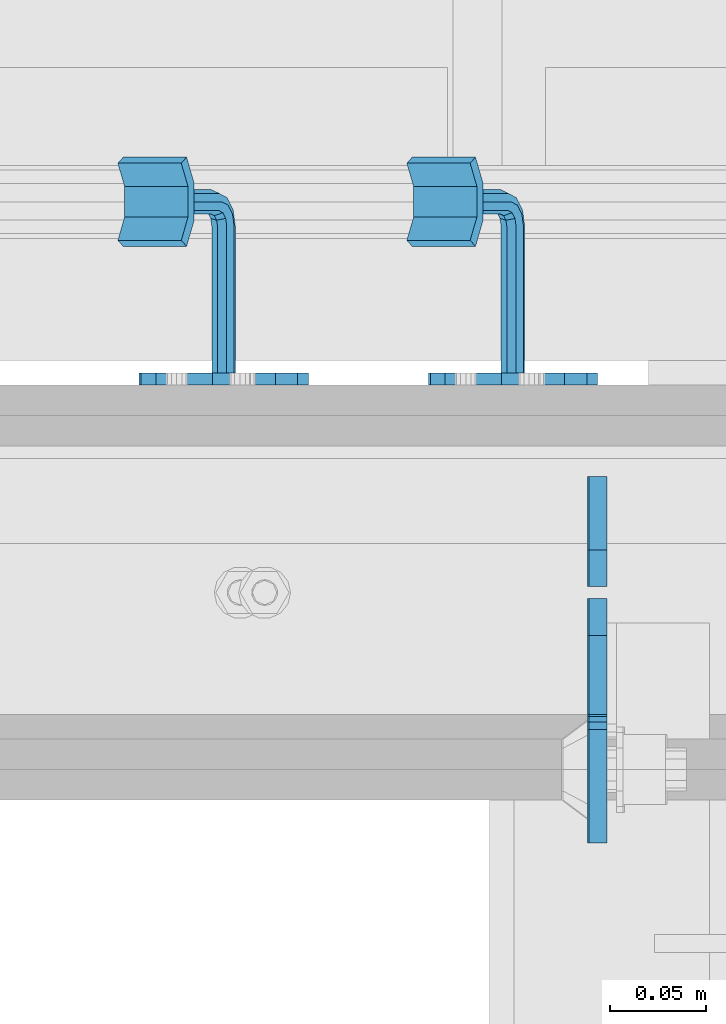
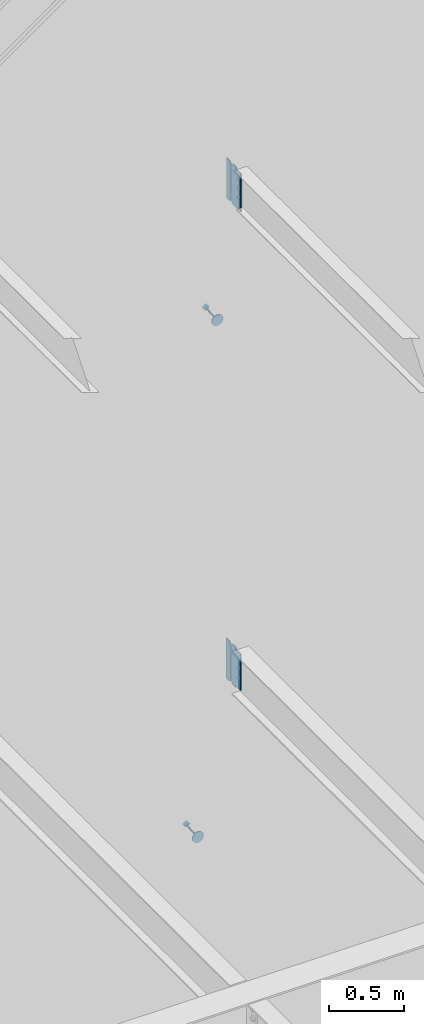
# One storey, part 1095 of 1179: 6 plates, 4 elements without a shape of their own.
"""IFC2X3 building model written with IfcOpenShell, lengths in millimetres."""

from ifc_helpers import new_model, si_unit, frame, origin_with_axes, place, context, subcontext, project, spatial, faceted_brep, material, type_object, element, aggregate, save


model = new_model("IFC2X3")

# Units and contexts
model_context = context("Model", 3, precision=1e-05, world=origin_with_axes())
body_context = subcontext(model_context, "Body", "Model", "MODEL_VIEW")
ifc_project = project(units=[si_unit("LENGTHUNIT", "METRE", prefix="MILLI"), si_unit("AREAUNIT", "SQUARE_METRE"), si_unit("VOLUMEUNIT", "CUBIC_METRE"), si_unit("MASSUNIT", "GRAM", prefix="KILO"), si_unit("TIMEUNIT", "SECOND"), si_unit("PLANEANGLEUNIT", "RADIAN"), si_unit("SOLIDANGLEUNIT", "STERADIAN"), si_unit("THERMODYNAMICTEMPERATUREUNIT", "DEGREE_CELSIUS"), si_unit("LUMINOUSINTENSITYUNIT", "LUMEN")], contexts=[model_context])

# Site, building, storey
site_placement = place(None, origin_with_axes())
site = spatial("IfcSite", under=ifc_project, at=site_placement, CompositionType="ELEMENT")
building_placement = place(site_placement, origin_with_axes())
building = spatial("IfcBuilding", under=site, at=building_placement, Name="Undefined", CompositionType="ELEMENT")
storey_placement = place(building_placement, origin_with_axes())
storey = spatial("IfcBuildingStorey", under=building, at=storey_placement, Name="Undefined", CompositionType="ELEMENT", Elevation=0.0)

# Assembly, plate
assembly_1_placement = place(storey_placement, origin_with_axes())
assembly_1 = element("IfcElementAssembly", 1, at=assembly_1_placement, inside=storey, Name="BEAM", AssemblyPlace="NOTDEFINED", PredefinedType="RIGID_FRAME")
ifc_material_1 = material(Name="STEEL/A36")
plate_type_1 = type_object("IfcPlateType", PredefinedType="NOTDEFINED")
plate_1_placement = place(assembly_1_placement, frame((22318.6620000839, 37982.525, 3762.375), z_axis=(0.0, 0.0, 1.0), x_axis=(0.0, -1.0, 0.0)))
plate_1 = element("IfcPlate", 2, at=plate_1_placement, type_object=plate_type_1, material=ifc_material_1, Name="PLATE", context=body_context, shape_type="Brep", body=[
    faceted_brep([(60.3249999999971, -4.76250000000073, 0.0), (60.3249999999971, 4.76250000000073, 0.0), (60.3250000523913, 4.76250000000073, 3.17500033034594), (60.3250000523913, -4.76250000000073, 3.17500033034594), (61.2917300150875, 4.76250000000073, 8.03507980551149), (61.2917300150875, -4.76250000000073, 8.03507980551149), (64.0447439248892, 4.76250000000073, 12.1552562262682), (64.0447439248892, -4.76250000000073, 12.1552562262682), (68.1649203759516, 4.76250000000073, 14.9082700907147), (68.1649203759516, -4.76250000000073, 14.9082700907147), (73.0249998617583, 4.76250000000073, 15.8749999999122), (73.0249998617583, -4.76250000000073, 15.8749999999122), (127.000004117435, -4.76250000000073, 15.8749999995416), (127.000004116067, 4.76250000000073, 15.8749999995416), (19.0499992370605, -4.76250000000073, 0.0), (0.0, -4.76250000000073, 19.0499992370605), (0.0, 4.76250000000073, 19.0499992370605), (19.0499992370605, 4.76250000000073, 0.0), (0.0, -4.76250000000073, 311.150012969971), (0.0, 4.76250000000073, 311.150012969971), (19.0499992370605, -4.76250000000073, 330.200012207031), (19.0499992370605, 4.76250000000073, 330.200012207031), (60.3250000095268, -4.76250000000073, 330.200000000001), (60.3250000095268, 4.76250000000073, 330.200000000001), (60.3250000714397, -4.76250000000073, 323.849999691947), (60.3250000714397, 4.76250000000073, 323.849999691947), (61.2917300265472, -4.76250000000073, 318.9899202097), (61.2917300265472, 4.76250000000073, 318.9899202097), (64.0447439338604, -4.76250000000073, 314.869743780706), (64.0447439338604, 4.76250000000073, 314.869743780706), (68.1649203869747, -4.76250000000073, 312.116729909506), (68.1649203869747, 4.76250000000073, 312.116729909506), (73.0249998776999, -4.76250000000073, 311.149999996991), (73.0249998776999, 4.76250000000073, 311.149999996991), (127.000004111091, -4.76250000000073, 311.149999984205), (127.000004116067, 4.76250000000073, 311.149999984205)], [[[0, 1, 2, 3]], [[3, 2, 4, 5]], [[5, 4, 6, 7]], [[7, 6, 8, 9]], [[9, 8, 10, 11]], [[12, 11, 10, 13]], [[14, 15, 16, 17]], [[15, 18, 19, 16]], [[18, 20, 21, 19]], [[21, 20, 22, 23]], [[22, 24, 25, 23]], [[26, 27, 25, 24]], [[28, 29, 27, 26]], [[30, 31, 29, 28]], [[32, 33, 31, 30]], [[34, 35, 33, 32]], [[35, 34, 12, 13]], [[8, 6, 4, 2, 1, 17, 16, 19, 21, 23, 25, 27, 29, 31, 33, 35, 13, 10]], [[0, 14, 17, 1]], [[34, 32, 30, 28, 26, 24, 22, 20, 18, 15, 14, 0, 3, 5, 7, 9, 11, 12]]]),
])

assembly_2_placement = place(storey_placement, origin_with_axes())
assembly_2 = element("IfcElementAssembly", 3, at=assembly_2_placement, inside=storey, Name="BEAM", AssemblyPlace="NOTDEFINED", PredefinedType="RIGID_FRAME")
plate_2_placement = place(assembly_2_placement, frame((22319.4556310585, 37982.525, 7673.975), z_axis=(0.0, 0.0, 1.0), x_axis=(0.0, -1.0, 0.0)))
plate_2 = element("IfcPlate", 4, at=plate_2_placement, type_object=plate_type_1, material=ifc_material_1, Name="PLATE", context=body_context, shape_type="Brep", body=[
    faceted_brep([(60.3250000095268, -4.76250000000073, 330.200000000001), (60.3249999999971, -4.76250000000073, 327.024999809266), (60.3249999999971, 4.76250000000073, 327.024999809266), (60.3250000095268, 4.76250000000073, 330.200000000001), (61.2917299225883, -4.76250000000073, 322.164920291219), (61.2917299225883, 4.76250000000073, 322.164920291219), (64.0447438230622, -4.76250000000073, 318.044743823066), (64.0447438230622, 4.76250000000073, 318.044743823066), (68.1649202912158, -4.76250000000073, 315.291729922588), (68.1649202912158, 4.76250000000073, 315.291729922588), (73.0249998092622, -4.76250000000073, 314.325000000001), (73.0249998092622, 4.76250000000073, 314.325000000001), (127.0, -4.76250000000073, 314.325000000001), (127.0, 4.76250000000073, 314.325000000001), (0.0, -4.76250000000073, 311.150012969971), (19.0499992370605, -4.76250000000073, 330.200012207031), (19.0499992370605, 4.76250000000073, 330.200012207031), (0.0, 4.76250000000073, 311.150012969971), (0.0, -4.76250000000073, 19.0499992370605), (0.0, 4.76250000000073, 19.0499992370605), (19.0499992370605, -4.76250000000073, 0.0), (19.0499992370605, 4.76250000000073, 0.0), (127.0, -4.76250000000073, 0.0), (127.0, 4.76250000000073, 0.0)], [[[0, 1, 2, 3]], [[4, 5, 2, 1]], [[6, 7, 5, 4]], [[8, 9, 7, 6]], [[10, 11, 9, 8]], [[12, 13, 11, 10]], [[14, 15, 16, 17]], [[18, 14, 17, 19]], [[20, 18, 19, 21]], [[22, 20, 21, 23]], [[8, 6, 4, 1, 0, 15, 14, 18, 20, 22, 12, 10]], [[16, 15, 0, 3]], [[23, 21, 19, 17, 16, 3, 2, 5, 7, 9, 11, 13]], [[22, 23, 13, 12]]]),
])

# Plate
plate_type_2 = type_object("IfcPlateType", PredefinedType="NOTDEFINED")
plate_3_placement = place(assembly_1_placement, frame((22318.6625, 37988.875, 3762.375), z_axis=(0.0, 0.0, 1.0), x_axis=(0.0, 1.0, 0.0)))
plate_3 = element("IfcPlate", 5, at=plate_3_placement, type_object=plate_type_2, material=ifc_material_1, Name="PLATE", context=body_context, shape_type="Brep", body=[
    faceted_brep([(0.0, -4.76250000000073, 19.0499992370605), (0.0, -4.76250000000073, 311.150012969971), (0.0, 4.76250000000073, 311.150012969971), (0.0, 4.76250000000073, 19.0499992370605), (19.0499992370605, -4.76250000000073, 330.200012207031), (19.0499992370605, 4.76250000000073, 330.200012207031), (57.1500015258789, -4.76250000000073, 330.200012207031), (57.1500015258789, 4.76250000000073, 330.200012207031), (57.1500015258789, -4.76250000000073, 0.0), (57.1500015258789, 4.76250000000073, 0.0), (19.0499992370605, -4.76250000000073, 0.0), (19.0499992370605, 4.76250000000073, 0.0)], [[[0, 1, 2, 3]], [[1, 4, 5, 2]], [[4, 6, 7, 5]], [[6, 8, 9, 7]], [[8, 10, 11, 9]], [[10, 0, 3, 11]], [[5, 7, 9, 11, 3, 2]], [[10, 8, 6, 4, 1, 0]]]),
])

aggregate(assembly_1, [plate_3, plate_1])

plate_4_placement = place(assembly_2_placement, frame((22319.4556310585, 37988.875, 7673.975), z_axis=(0.0, 0.0, 1.0), x_axis=(0.0, 1.0, 0.0)))
plate_4 = element("IfcPlate", 6, at=plate_4_placement, type_object=plate_type_2, material=ifc_material_1, Name="PLATE", context=body_context, shape_type="Brep", body=[
    faceted_brep([(0.0, -4.76250000000073, 19.0499992370605), (0.0, -4.76250000000073, 311.150012969971), (0.0, 4.76250000000073, 311.150012969971), (0.0, 4.76250000000073, 19.0499992370605), (19.0499992370605, -4.76250000000073, 330.200012207031), (19.0499992370605, 4.76250000000073, 330.200012207031), (57.1500015258789, -4.76250000000073, 330.200012207031), (57.1500015258789, 4.76250000000073, 330.200012207031), (57.1500015258789, -4.76250000000073, 0.0), (57.1500015258789, 4.76250000000073, 0.0), (19.0499992370605, -4.76250000000073, 0.0), (19.0499992370605, 4.76250000000073, 0.0)], [[[0, 1, 2, 3]], [[1, 4, 5, 2]], [[4, 6, 7, 5]], [[6, 8, 9, 7]], [[8, 10, 11, 9]], [[10, 0, 3, 11]], [[5, 7, 9, 11, 3, 2]], [[10, 8, 6, 4, 1, 0]]]),
])

aggregate(assembly_2, [plate_4, plate_2])

# Assembly, plate
assembly_3_placement = place(storey_placement, origin_with_axes())
assembly_3 = element("IfcElementAssembly", 7, at=assembly_3_placement, inside=storey, Name="HANDRAIL", AssemblyPlace="NOTDEFINED", PredefinedType="RIGID_FRAME")
ifc_material_2 = material(Name="STEEL/BUY-OUT")
plate_type_3 = type_object("IfcPlateType", PredefinedType="NOTDEFINED")
plate_5_placement = place(assembly_3_placement, frame((22335.9601757589, 38096.8249999748, 6649.21021440539), z_axis=(-0.503209296841367, 0.0, 0.864164569727559), x_axis=(-0.864164569727559, 0.0, -0.503209296841368)))
plate_5 = element("IfcPlate", 8, at=plate_5_placement, type_object=plate_type_3, material=ifc_material_2, Name="BRACKET", context=body_context, shape_type="Brep", body=[
    faceted_brep([(3.38355483805572, -3.17500000000291, 61.4602780976829), (13.0191037998557, -3.17500000000291, 75.8808962003231), (13.0191037998557, 3.17500000000291, 75.8808962003231), (3.38355483805572, 3.17500000000291, 61.4602780976829), (27.439721902505, -3.17500000000291, 85.5164451621013), (27.439721902505, 3.17500000000291, 85.5164451621013), (44.449999237233, -3.17500000000291, 88.900000000056), (44.449999237233, 3.17500000000291, 88.900000000056), (61.4602780978275, -3.17500000000291, 85.5164451621104), (61.4602780978275, 3.17500000000291, 85.5164451621104), (75.8808962004478, -3.17500000000291, 75.8808962003413), (75.8808962004478, 3.17500000000291, 75.8808962003413), (85.5164451621931, -3.17500000000291, 61.4602780977075), (85.5164451621931, 3.17500000000291, 61.4602780977075), (88.9000000001142, -3.17500000000291, 44.4500007629867), (88.9000000001142, 3.17500000000291, 44.4500007629867), (85.5164451621349, -3.17500000000291, 27.4397219023849), (85.5164451621349, 3.17500000000291, 27.4397219023849), (75.880896200335, -3.17500000000291, 13.0191037997447), (75.880896200335, 3.17500000000291, 13.0191037997447), (61.460278097682, -3.17500000000291, 3.38355483796659), (61.460278097682, 3.17500000000291, 3.38355483796659), (44.450000762954, -3.17500000000291, 1.18234311230481e-11), (44.450000762954, 3.17500000000291, 1.18234311230481e-11), (27.4397219023631, -3.17500000000291, 3.38355483795749), (27.4397219023631, 3.17500000000291, 3.38355483795749), (13.0191037997429, -3.17500000000291, 13.0191037997274), (13.0191037997429, 3.17500000000291, 13.0191037997274), (3.38355483799751, -3.17500000000291, 27.4397219023613), (3.38355483799751, 3.17500000000291, 27.4397219023613), (7.6397554948926e-11, -3.17500000000291, 44.4500007629631), (7.6397554948926e-11, 3.17500000000291, 44.4500007629631), (50.7999999913809, -79.375000189706, 44.450000918423), (48.9401280518978, -79.375000189706, 39.9598728578721), (48.9401280518978, -3.17500000000291, 39.9598728578721), (50.7999999913809, -3.17500000000291, 44.450000918423), (44.4499999913533, -79.375000189706, 38.1000009183936), (44.4499999913533, -3.17500000000291, 38.1000009183936), (39.9598719308196, -79.375000189706, 39.9598728578549), (39.9598719308196, -3.17500000000291, 39.9598728578549), (38.0999999913656, -79.375000189706, 44.4500009184003), (38.0999999913656, -3.17500000000291, 44.4500009184003), (39.9598719308487, -79.375000189706, 48.940128978953), (39.9598719308487, -3.17500000000291, 48.940128978953), (44.4499999903783, -79.375000189706, 50.8000009184298), (48.9401280519305, -79.375000189706, 48.9401289789685), (48.9401280519305, -3.17500000000291, 48.9401289789685), (44.4499999913933, -3.17500000000291, 50.8000009184325), (48.940128050941, -83.4799360644611, 50.0400432323731), (50.7999999909662, -85.7250000949134, 46.1514782660752), (48.9401280520542, -87.9700641252057, 42.2629132991351), (44.4499999917462, -88.9000000947854, 40.6522169510108), (39.9598719309761, -87.9700641248055, 42.2629132975717), (38.0999999909509, -85.7250000943604, 46.1514782638696), (39.9598719298592, -83.4799360640682, 50.0400432308115), (44.4499999901709, -82.5500000944885, 51.6507395789349), (44.4499999895997, -84.8742613387294, 53.9750008233668), (48.9401280502061, -86.4849576864799, 53.0450648546439), (39.9598719291243, -86.4849576858032, 53.0450648527949), (38.0999999898122, -90.3735226524441, 50.8000008223462), (39.9598719294336, -94.262087619376, 48.554936792666), (44.4499999900399, -95.8727839671337, 47.6250008239376), (48.9401280505153, -94.2620876200599, 48.5549367945105), (50.7999999898311, -90.3735226534118, 50.8000008249601), (48.940128049202, -87.5848719388305, 57.150000729499), (50.7999999882741, -92.0749999995314, 57.1500007303257), (44.4499999882682, -85.7249999989726, 57.1500007282275), (39.9598719281203, -87.5848719380447, 57.1500007272562), (38.0999999882624, -92.0749999984182, 57.1500007271543), (39.9598719273345, -96.5651280591119, 57.150000727981), (44.4499999877116, -98.4249999989697, 57.1500007292507), (48.9401280484162, -96.5651280598977, 57.150000730222), (48.94012803636, -96.5651280554303, 107.980205186974), (50.7999999758504, -92.0749999949039, 107.980205187367), (44.4499999758082, -98.4249999948734, 107.980205185997), (39.9598719152818, -96.5651280553866, 107.980205185009), (38.0999999758387, -92.0749999948384, 107.980205184591), (39.9598719153255, -87.5848719343194, 107.980205184981), (44.4499999758445, -85.7249999948763, 107.980205185959), (48.9401280364073, -87.584871934363, 107.980205186946), (63.4999999710089, -112.173153287971, 121.386761918008), (25.3999999709486, -112.173153273812, 121.386761909694), (25.3999999709413, -115.348153273233, 115.887500595331), (63.499999970998, -115.348153287392, 115.887500603646), (63.4999999770953, -99.950838506069, 114.330205190187), (25.3999999770385, -99.9508384918445, 114.330205181834), (63.4999999830179, -84.3037932516017, 114.330205190117), (25.3999999829539, -84.3037932373336, 114.330205181805), (63.4999999860993, -72.081478471373, 121.386761924126), (25.3999999860353, -72.0814784571267, 121.386761915784), (25.3999999849657, -82.6023158642492, 107.980205181794), (25.3999999777625, -101.652315863423, 107.98020518183), (25.3999999884181, -68.9064784552756, 115.887500602809), (63.4999999778265, -101.652315877654, 107.980205190185), (63.4999999850261, -82.6023158785247, 107.980205190103), (63.4999999884785, -68.906478469522, 115.887500611152)], [[[0, 1, 2, 3]], [[1, 4, 5, 2]], [[4, 6, 7, 5]], [[6, 8, 9, 7]], [[8, 10, 11, 9]], [[10, 12, 13, 11]], [[12, 14, 15, 13]], [[14, 16, 17, 15]], [[16, 18, 19, 17]], [[18, 20, 21, 19]], [[20, 22, 23, 21]], [[22, 24, 25, 23]], [[24, 26, 27, 25]], [[26, 28, 29, 27]], [[28, 30, 31, 29]], [[2, 5, 7, 9, 11, 13, 15, 17, 19, 21, 23, 25, 27, 29, 31, 3]], [[30, 0, 3, 31]], [[32, 33, 34, 35]], [[33, 36, 37, 34]], [[36, 38, 39, 37]], [[38, 40, 41, 39]], [[40, 42, 43, 41]], [[44, 45, 46, 47]], [[42, 44, 47, 43]], [[28, 26, 24, 22, 20, 18, 16, 14, 12, 10, 8, 6, 4, 1, 0, 30], [46, 35, 34, 37, 39, 41, 43, 47]], [[45, 32, 35, 46]], [[32, 45, 48, 49]], [[33, 32, 49, 50]], [[36, 33, 50, 51]], [[38, 36, 51, 52]], [[40, 38, 52, 53]], [[42, 40, 53, 54]], [[44, 42, 54, 55]], [[45, 44, 55, 48]], [[55, 56, 57, 48]], [[54, 58, 56, 55]], [[53, 59, 58, 54]], [[52, 60, 59, 53]], [[51, 61, 60, 52]], [[50, 62, 61, 51]], [[49, 63, 62, 50]], [[48, 57, 63, 49]], [[57, 64, 65, 63]], [[56, 66, 64, 57]], [[58, 67, 66, 56]], [[59, 68, 67, 58]], [[60, 69, 68, 59]], [[61, 70, 69, 60]], [[62, 71, 70, 61]], [[63, 65, 71, 62]], [[72, 71, 65, 73]], [[74, 70, 71, 72]], [[75, 69, 70, 74]], [[76, 68, 69, 75]], [[77, 67, 68, 76]], [[78, 66, 67, 77]], [[79, 64, 66, 78]], [[73, 65, 64, 79]], [[80, 81, 82, 83]], [[81, 80, 84, 85]], [[85, 84, 86, 87]], [[87, 86, 88, 89]], [[90, 91, 82, 81, 85, 87, 89, 92]], [[83, 82, 91, 93]], [[86, 84, 80, 83, 93, 94, 95, 88]], [[89, 88, 95, 92]], [[94, 90, 92, 95]], [[93, 91, 90, 94], [78, 77, 76, 75, 74, 72, 73, 79]]]),
])
aggregate(assembly_3, [plate_5])

assembly_4_placement = place(storey_placement, origin_with_axes())
assembly_4 = element("IfcElementAssembly", 9, at=assembly_4_placement, inside=storey, Name="HANDRAIL", AssemblyPlace="NOTDEFINED", PredefinedType="RIGID_FRAME")
plate_6_placement = place(assembly_4_placement, frame((22185.4054812551, 38096.8249999748, 2491.04272053199), z_axis=(-0.500231016985973, 0.0, 0.865891984975712), x_axis=(-0.865891984975713, 0.0, -0.500231016985972)))
plate_6 = element("IfcPlate", 10, at=plate_6_placement, type_object=plate_type_3, material=ifc_material_2, Name="BRACKET", context=body_context, shape_type="Brep", body=[
    faceted_brep([(3.38355483805572, -3.17500000000291, 61.4602780976829), (13.0191037998557, -3.17500000000291, 75.8808962003231), (13.0191037998557, 3.17500000000291, 75.8808962003231), (3.38355483805572, 3.17500000000291, 61.4602780976829), (27.439721902505, -3.17500000000291, 85.5164451621013), (27.439721902505, 3.17500000000291, 85.5164451621013), (44.449999237233, -3.17500000000291, 88.900000000056), (44.449999237233, 3.17500000000291, 88.900000000056), (61.4602780978275, -3.17500000000291, 85.5164451621104), (61.4602780978275, 3.17500000000291, 85.5164451621104), (75.8808962004478, -3.17500000000291, 75.8808962003413), (75.8808962004478, 3.17500000000291, 75.8808962003413), (85.5164451621931, -3.17500000000291, 61.4602780977075), (85.5164451621931, 3.17500000000291, 61.4602780977075), (88.9000000001142, -3.17500000000291, 44.4500007629867), (88.9000000001142, 3.17500000000291, 44.4500007629867), (85.5164451621349, -3.17500000000291, 27.4397219023849), (85.5164451621349, 3.17500000000291, 27.4397219023849), (75.880896200335, -3.17500000000291, 13.0191037997447), (75.880896200335, 3.17500000000291, 13.0191037997447), (61.460278097682, -3.17500000000291, 3.38355483796659), (61.460278097682, 3.17500000000291, 3.38355483796659), (44.450000762954, -3.17500000000291, 1.18234311230481e-11), (44.450000762954, 3.17500000000291, 1.18234311230481e-11), (27.4397219023631, -3.17500000000291, 3.38355483795749), (27.4397219023631, 3.17500000000291, 3.38355483795749), (13.0191037997429, -3.17500000000291, 13.0191037997274), (13.0191037997429, 3.17500000000291, 13.0191037997274), (3.38355483799751, -3.17500000000291, 27.4397219023613), (3.38355483799751, 3.17500000000291, 27.4397219023613), (7.6397554948926e-11, -3.17500000000291, 44.4500007629631), (7.6397554948926e-11, 3.17500000000291, 44.4500007629631), (50.7999999913809, -79.375000189706, 44.450000918423), (48.9401280518978, -79.375000189706, 39.9598728578721), (48.9401280518978, -3.17500000000291, 39.9598728578721), (50.7999999913809, -3.17500000000291, 44.450000918423), (44.4499999913533, -79.375000189706, 38.1000009183936), (44.4499999913533, -3.17500000000291, 38.1000009183936), (39.9598719308196, -79.375000189706, 39.9598728578549), (39.9598719308196, -3.17500000000291, 39.9598728578549), (38.0999999913656, -79.375000189706, 44.4500009184003), (38.0999999913656, -3.17500000000291, 44.4500009184003), (39.9598719308487, -79.375000189706, 48.940128978953), (39.9598719308487, -3.17500000000291, 48.940128978953), (44.4499999903783, -79.375000189706, 50.8000009184298), (48.9401280519305, -79.375000189706, 48.9401289789685), (48.9401280519305, -3.17500000000291, 48.9401289789685), (44.4499999913933, -3.17500000000291, 50.8000009184325), (48.940128050941, -83.4799360644611, 50.0400432323731), (50.7999999909662, -85.7250000949134, 46.1514782660752), (48.9401280520542, -87.9700641252057, 42.2629132991351), (44.4499999917462, -88.9000000947854, 40.6522169510108), (39.9598719309761, -87.9700641248055, 42.2629132975717), (38.0999999909509, -85.7250000943604, 46.1514782638696), (39.9598719298592, -83.4799360640682, 50.0400432308115), (44.4499999901709, -82.5500000944885, 51.6507395789349), (44.4499999895997, -84.8742613387294, 53.9750008233668), (48.9401280502061, -86.4849576864799, 53.0450648546439), (39.9598719291243, -86.4849576858032, 53.0450648527949), (38.0999999898122, -90.3735226524441, 50.8000008223462), (39.9598719294336, -94.262087619376, 48.554936792666), (44.4499999900399, -95.8727839671337, 47.6250008239376), (48.9401280505153, -94.2620876200599, 48.5549367945105), (50.7999999898311, -90.3735226534118, 50.8000008249601), (48.940128049202, -87.5848719388305, 57.150000729499), (50.7999999882741, -92.0749999995314, 57.1500007303257), (44.4499999882682, -85.7249999989726, 57.1500007282275), (39.9598719281203, -87.5848719380447, 57.1500007272562), (38.0999999882624, -92.0749999984182, 57.1500007271543), (39.9598719273345, -96.5651280591119, 57.150000727981), (44.4499999877116, -98.4249999989697, 57.1500007292507), (48.9401280484162, -96.5651280598977, 57.150000730222), (48.94012803636, -96.5651280554303, 107.980205186974), (50.7999999758504, -92.0749999949039, 107.980205187367), (44.4499999758082, -98.4249999948734, 107.980205185997), (39.9598719152818, -96.5651280553866, 107.980205185009), (38.0999999758387, -92.0749999948384, 107.980205184591), (39.9598719153255, -87.5848719343194, 107.980205184981), (44.4499999758445, -85.7249999948763, 107.980205185959), (48.9401280364073, -87.584871934363, 107.980205186946), (63.4999999710089, -112.173153287971, 121.386761918008), (25.3999999709486, -112.173153273812, 121.386761909694), (25.3999999709413, -115.348153273233, 115.887500595331), (63.499999970998, -115.348153287392, 115.887500603646), (63.4999999770953, -99.950838506069, 114.330205190187), (25.3999999770385, -99.9508384918445, 114.330205181834), (63.4999999830179, -84.3037932516017, 114.330205190117), (25.3999999829539, -84.3037932373336, 114.330205181805), (63.4999999860993, -72.081478471373, 121.386761924126), (25.3999999860353, -72.0814784571267, 121.386761915784), (25.3999999849657, -82.6023158642492, 107.980205181794), (25.3999999777625, -101.652315863423, 107.98020518183), (25.3999999884181, -68.9064784552756, 115.887500602809), (63.4999999778265, -101.652315877654, 107.980205190185), (63.4999999850261, -82.6023158785247, 107.980205190103), (63.4999999884785, -68.906478469522, 115.887500611152)], [[[0, 1, 2, 3]], [[1, 4, 5, 2]], [[4, 6, 7, 5]], [[6, 8, 9, 7]], [[8, 10, 11, 9]], [[10, 12, 13, 11]], [[12, 14, 15, 13]], [[14, 16, 17, 15]], [[16, 18, 19, 17]], [[18, 20, 21, 19]], [[20, 22, 23, 21]], [[22, 24, 25, 23]], [[24, 26, 27, 25]], [[26, 28, 29, 27]], [[28, 30, 31, 29]], [[2, 5, 7, 9, 11, 13, 15, 17, 19, 21, 23, 25, 27, 29, 31, 3]], [[30, 0, 3, 31]], [[32, 33, 34, 35]], [[33, 36, 37, 34]], [[36, 38, 39, 37]], [[38, 40, 41, 39]], [[40, 42, 43, 41]], [[44, 45, 46, 47]], [[42, 44, 47, 43]], [[28, 26, 24, 22, 20, 18, 16, 14, 12, 10, 8, 6, 4, 1, 0, 30], [46, 35, 34, 37, 39, 41, 43, 47]], [[45, 32, 35, 46]], [[32, 45, 48, 49]], [[33, 32, 49, 50]], [[36, 33, 50, 51]], [[38, 36, 51, 52]], [[40, 38, 52, 53]], [[42, 40, 53, 54]], [[44, 42, 54, 55]], [[45, 44, 55, 48]], [[55, 56, 57, 48]], [[54, 58, 56, 55]], [[53, 59, 58, 54]], [[52, 60, 59, 53]], [[51, 61, 60, 52]], [[50, 62, 61, 51]], [[49, 63, 62, 50]], [[48, 57, 63, 49]], [[57, 64, 65, 63]], [[56, 66, 64, 57]], [[58, 67, 66, 56]], [[59, 68, 67, 58]], [[60, 69, 68, 59]], [[61, 70, 69, 60]], [[62, 71, 70, 61]], [[63, 65, 71, 62]], [[72, 71, 65, 73]], [[74, 70, 71, 72]], [[75, 69, 70, 74]], [[76, 68, 69, 75]], [[77, 67, 68, 76]], [[78, 66, 67, 77]], [[79, 64, 66, 78]], [[73, 65, 64, 79]], [[80, 81, 82, 83]], [[81, 80, 84, 85]], [[85, 84, 86, 87]], [[87, 86, 88, 89]], [[90, 91, 82, 81, 85, 87, 89, 92]], [[83, 82, 91, 93]], [[86, 84, 80, 83, 93, 94, 95, 88]], [[89, 88, 95, 92]], [[94, 90, 92, 95]], [[93, 91, 90, 94], [78, 77, 76, 75, 74, 72, 73, 79]]]),
])
aggregate(assembly_4, [plate_6])

save(model, "model.ifc")
